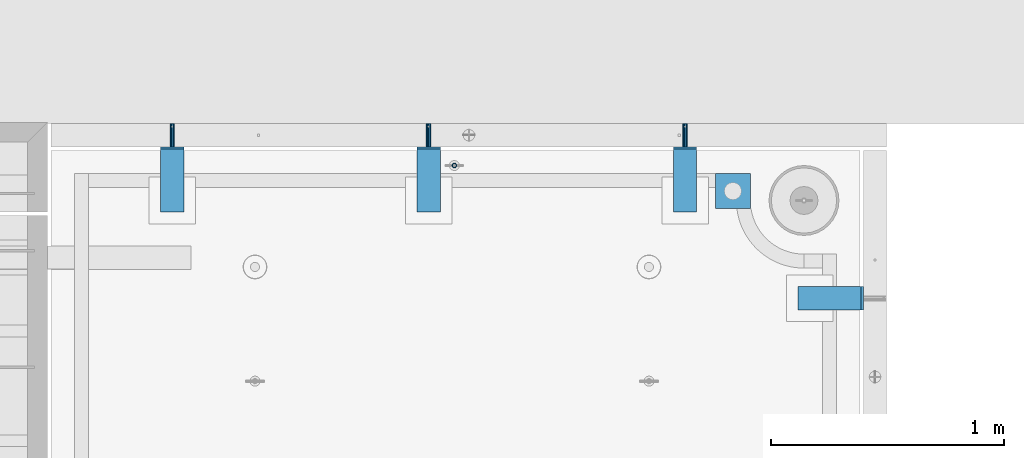
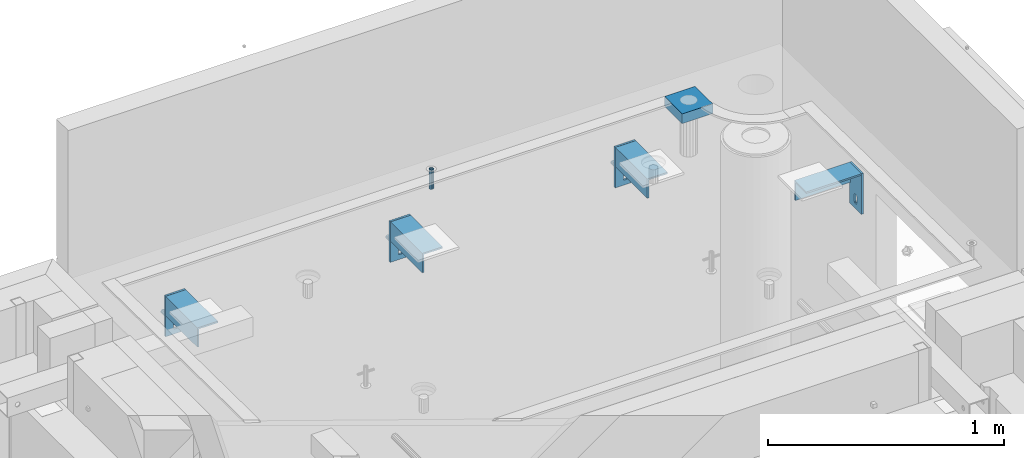
# One storey, part 114 of 264: 13 beams, 14 elements without a shape of their own.
"""IFC2X3 building model written with IfcOpenShell, lengths in millimetres."""

from ifc_helpers import new_model, si_unit, frame, origin_with_axes, place, context, subcontext, project, spatial, faceted_brep, material, type_object, element, aggregate, save


model = new_model("IFC2X3")

# Units and contexts
model_context = context("Model", 3, precision=1e-05, world=origin_with_axes())
body_context = subcontext(model_context, "Body", "Model", "MODEL_VIEW")
ifc_project = project(units=[si_unit("LENGTHUNIT", "METRE", prefix="MILLI"), si_unit("AREAUNIT", "SQUARE_METRE"), si_unit("VOLUMEUNIT", "CUBIC_METRE"), si_unit("MASSUNIT", "GRAM", prefix="KILO"), si_unit("TIMEUNIT", "SECOND"), si_unit("PLANEANGLEUNIT", "RADIAN"), si_unit("SOLIDANGLEUNIT", "STERADIAN"), si_unit("THERMODYNAMICTEMPERATUREUNIT", "DEGREE_CELSIUS"), si_unit("LUMINOUSINTENSITYUNIT", "LUMEN")], contexts=[model_context])

# Site, building, storey
site_placement = place(None, origin_with_axes())
site = spatial("IfcSite", under=ifc_project, at=site_placement, CompositionType="ELEMENT")
building_placement = place(site_placement, origin_with_axes())
building = spatial("IfcBuilding", under=site, at=building_placement, CompositionType="ELEMENT")
storey_placement = place(building_placement, origin_with_axes())
storey = spatial("IfcBuildingStorey", under=building, at=storey_placement, Name="K", CompositionType="ELEMENT", Elevation=0.0)

# Assembly, beam
assembly_1_placement = place(storey_placement, origin_with_axes())
assembly_1 = element("IfcElementAssembly", 1, at=assembly_1_placement, inside=storey, AssemblyPlace="NOTDEFINED", PredefinedType="REINFORCEMENT_UNIT")
ifc_material_1 = material(Name="CONCRETE/Concrete_Undefined")
beam_type_1 = type_object("IfcBeamType", PredefinedType="NOTDEFINED")
beam_1_placement = place(assembly_1_placement, frame((34629.9388785763, 22710.0581582943, 81683.7829850799), z_axis=(-0.00137996799978526, 4.79999998713041e-07, 0.999999047843591), x_axis=(0.999998987436327, -0.000347584000148161, 0.00137996800063524)))
beam_1 = element("IfcBeam", 2, at=beam_1_placement, type_object=beam_type_1, material=ifc_material_1, context=body_context, shape_type="Brep", body=[
    faceted_brep([(0.0, 75.0, -25.0), (1.81898940354586e-12, 75.0, 25.0), (149.995899162379, 75.0, 25.0), (149.995899158246, 75.0000000000036, -25.0), (1.81898940354586e-12, -75.0000000000009, 25.0), (149.995899162386, -75.0, 25.0), (0.0, -75.0, -25.0), (149.995899158239, -74.9999999999964, -25.0)], [[[0, 1, 2, 3]], [[1, 4, 5, 2]], [[4, 6, 7, 5]], [[6, 0, 3, 7]], [[5, 7, 3, 2]], [[6, 4, 1, 0]]]),
])

# Assemblies, beams
assembly_2_placement = place(storey_placement, origin_with_axes())
assembly_2 = element("IfcElementAssembly", 3, at=assembly_2_placement, inside=storey, AssemblyPlace="NOTDEFINED", PredefinedType="REINFORCEMENT_UNIT")
assembly_3_placement = place(assembly_2_placement, origin_with_axes())
assembly_3 = element("IfcElementAssembly", 4, at=assembly_3_placement, Name="Steel Assembly", AssemblyPlace="NOTDEFINED", PredefinedType="RIGID_FRAME")
ifc_material_2 = material(Name="STEEL/1.4301")
beam_type_2 = type_object("IfcBeamType", PredefinedType="NOTDEFINED")
beam_2_placement = place(assembly_3_placement, frame((32299.9965310378, 22900.0002194488, 81285.0), z_axis=(1.0, 0.0, 0.0), x_axis=(0.0, 1.0, 0.0)))
beam_2 = element("IfcBeam", 5, at=beam_2_placement, type_object=beam_type_2, material=ifc_material_2, context=body_context, shape_type="Brep", body=[
    faceted_brep([(0.0, -8.49999999999272, -1.45519152283669e-11), (0.0, -7.36121593215648, 4.24999999998545), (100.000000000262, -7.36121593215648, 4.24999999998545), (100.000000000262, -8.49999999999272, -1.45519152283669e-11), (0.0, -4.24999999998545, 7.36121593216376), (100.000000000262, -4.24999999998545, 7.36121593216376), (0.0, 1.45519152283669e-11, 8.49999999998545), (100.000000000262, 1.45519152283669e-11, 8.49999999998545), (0.0, 4.25000000001455, 7.36121593216376), (100.000000000262, 4.25000000001455, 7.36121593216376), (0.0, 7.36121593217104, 4.24999999998545), (100.000000000262, 7.36121593217104, 4.24999999998545), (0.0, 8.50000000000728, 0.0), (100.000000000262, 8.50000000000728, 0.0), (0.0, 7.36121593217104, -4.25000000001455), (100.000000000262, 7.36121593217104, -4.25000000001455), (0.0, 4.25000000000728, -7.36121593219286), (100.000000000262, 4.25000000000728, -7.36121593219286), (0.0, 7.27595761418343e-12, -8.5), (100.000000000262, 7.27595761418343e-12, -8.5), (0.0, -4.24999999999272, -7.36121593217831), (100.000000000262, -4.24999999999272, -7.36121593217831), (0.0, -7.36121593215648, -4.25), (100.000000000262, -7.36121593215648, -4.25), (0.0, -10.4999999999927, -1.45519152283669e-11), (0.0, -9.09326673972828, -5.25000000001455), (100.000000000262, -9.09326673972828, -5.25000000001455), (100.000000000262, -10.4999999999927, -1.45519152283669e-11), (0.0, -5.24999999998545, -9.09326673974283), (100.000000000262, -5.24999999998545, -9.09326673974283), (0.0, 7.27595761418343e-12, -10.5), (100.000000000262, 7.27595761418343e-12, -10.5), (0.0, 5.25000000001455, -9.09326673975738), (100.000000000262, 5.25000000001455, -9.09326673975738), (0.0, 9.09326673975011, -5.25000000001455), (100.000000000262, 9.09326673975011, -5.25000000001455), (0.0, 10.5000000000073, -1.45519152283669e-11), (100.000000000262, 10.5000000000073, -1.45519152283669e-11), (0.0, 9.09326673975011, 5.25), (100.000000000262, 9.09326673975011, 5.25), (0.0, 5.25000000000728, 9.09326673972828), (100.000000000262, 5.25000000000728, 9.09326673972828), (0.0, 1.45519152283669e-11, 10.4999999999854), (100.000000000262, 1.45519152283669e-11, 10.4999999999854), (0.0, -5.24999999999272, 9.09326673972828), (100.000000000262, -5.24999999999272, 9.09326673972828), (0.0, -9.09326673972828, 5.24999999998545), (100.000000000262, -9.09326673972828, 5.24999999998545)], [[[0, 1, 2, 3]], [[1, 4, 5, 2]], [[4, 6, 7, 5]], [[6, 8, 9, 7]], [[8, 10, 11, 9]], [[10, 12, 13, 11]], [[12, 14, 15, 13]], [[14, 16, 17, 15]], [[16, 18, 19, 17]], [[18, 20, 21, 19]], [[20, 22, 23, 21]], [[22, 0, 3, 23]], [[24, 25, 26, 27]], [[25, 28, 29, 26]], [[28, 30, 31, 29]], [[30, 32, 33, 31]], [[32, 34, 35, 33]], [[34, 36, 37, 35]], [[36, 38, 39, 37]], [[38, 40, 41, 39]], [[40, 42, 43, 41]], [[42, 44, 45, 43]], [[44, 46, 47, 45]], [[46, 24, 27, 47]], [[29, 31, 33, 35, 37, 39, 41, 43, 45, 47, 27, 26], [5, 7, 9, 11, 13, 15, 17, 19, 21, 23, 3, 2]], [[46, 44, 42, 40, 38, 36, 34, 32, 30, 28, 25, 24], [22, 20, 18, 16, 14, 12, 10, 8, 6, 4, 1, 0]]]),
])
aggregate(assembly_3, [beam_2])
assembly_4_placement = place(assembly_2_placement, origin_with_axes())
assembly_4 = element("IfcElementAssembly", 6, at=assembly_4_placement, Name="Steel Assembly", AssemblyPlace="NOTDEFINED", PredefinedType="RIGID_FRAME")
beam_3_placement = place(assembly_4_placement, frame((33399.9965310378, 22900.0002194488, 81285.0), z_axis=(1.0, 0.0, 0.0), x_axis=(0.0, 1.0, 0.0)))
beam_3 = element("IfcBeam", 7, at=beam_3_placement, type_object=beam_type_2, material=ifc_material_2, context=body_context, shape_type="Brep", body=[
    faceted_brep([(0.0, -8.49999999999272, -1.45519152283669e-11), (0.0, -7.36121593215648, 4.24999999998545), (100.000000000262, -7.36121593215648, 4.24999999998545), (100.000000000262, -8.49999999999272, -1.45519152283669e-11), (0.0, -4.24999999998545, 7.36121593216376), (100.000000000262, -4.24999999998545, 7.36121593216376), (0.0, 1.45519152283669e-11, 8.49999999998545), (100.000000000262, 1.45519152283669e-11, 8.49999999998545), (0.0, 4.25000000001455, 7.36121593216376), (100.000000000262, 4.25000000001455, 7.36121593216376), (0.0, 7.36121593217104, 4.24999999998545), (100.000000000262, 7.36121593217104, 4.24999999998545), (0.0, 8.50000000000728, 0.0), (100.000000000262, 8.50000000000728, 0.0), (0.0, 7.36121593217104, -4.25000000001455), (100.000000000262, 7.36121593217104, -4.25000000001455), (0.0, 4.25000000000728, -7.36121593219286), (100.000000000262, 4.25000000000728, -7.36121593219286), (0.0, 7.27595761418343e-12, -8.5), (100.000000000262, 7.27595761418343e-12, -8.5), (0.0, -4.24999999999272, -7.36121593217831), (100.000000000262, -4.24999999999272, -7.36121593217831), (0.0, -7.36121593215648, -4.25), (100.000000000262, -7.36121593215648, -4.25), (0.0, -10.4999999999927, -1.45519152283669e-11), (0.0, -9.09326673972828, -5.25000000001455), (100.000000000262, -9.09326673972828, -5.25000000001455), (100.000000000262, -10.4999999999927, -1.45519152283669e-11), (0.0, -5.24999999998545, -9.09326673974283), (100.000000000262, -5.24999999998545, -9.09326673974283), (0.0, 7.27595761418343e-12, -10.5), (100.000000000262, 7.27595761418343e-12, -10.5), (0.0, 5.25000000001455, -9.09326673975738), (100.000000000262, 5.25000000001455, -9.09326673975738), (0.0, 9.09326673975011, -5.25000000001455), (100.000000000262, 9.09326673975011, -5.25000000001455), (0.0, 10.5000000000073, -1.45519152283669e-11), (100.000000000262, 10.5000000000073, -1.45519152283669e-11), (0.0, 9.09326673975011, 5.25), (100.000000000262, 9.09326673975011, 5.25), (0.0, 5.25000000000728, 9.09326673972828), (100.000000000262, 5.25000000000728, 9.09326673972828), (0.0, 1.45519152283669e-11, 10.4999999999854), (100.000000000262, 1.45519152283669e-11, 10.4999999999854), (0.0, -5.24999999999272, 9.09326673972828), (100.000000000262, -5.24999999999272, 9.09326673972828), (0.0, -9.09326673972828, 5.24999999998545), (100.000000000262, -9.09326673972828, 5.24999999998545)], [[[0, 1, 2, 3]], [[1, 4, 5, 2]], [[4, 6, 7, 5]], [[6, 8, 9, 7]], [[8, 10, 11, 9]], [[10, 12, 13, 11]], [[12, 14, 15, 13]], [[14, 16, 17, 15]], [[16, 18, 19, 17]], [[18, 20, 21, 19]], [[20, 22, 23, 21]], [[22, 0, 3, 23]], [[24, 25, 26, 27]], [[25, 28, 29, 26]], [[28, 30, 31, 29]], [[30, 32, 33, 31]], [[32, 34, 35, 33]], [[34, 36, 37, 35]], [[36, 38, 39, 37]], [[38, 40, 41, 39]], [[40, 42, 43, 41]], [[42, 44, 45, 43]], [[44, 46, 47, 45]], [[46, 24, 27, 47]], [[29, 31, 33, 35, 37, 39, 41, 43, 45, 47, 27, 26], [5, 7, 9, 11, 13, 15, 17, 19, 21, 23, 3, 2]], [[46, 44, 42, 40, 38, 36, 34, 32, 30, 28, 25, 24], [22, 20, 18, 16, 14, 12, 10, 8, 6, 4, 1, 0]]]),
])
aggregate(assembly_4, [beam_3])
assembly_5_placement = place(assembly_2_placement, origin_with_axes())
assembly_5 = element("IfcElementAssembly", 8, at=assembly_5_placement, Name="Steel Assembly", AssemblyPlace="NOTDEFINED", PredefinedType="RIGID_FRAME")
aggregate(assembly_2, [assembly_3, assembly_4, assembly_5])
beam_4_placement = place(assembly_5_placement, frame((34499.9965310378, 22900.0002194488, 81285.0), z_axis=(1.0, 0.0, 0.0), x_axis=(0.0, 1.0, 0.0)))
beam_4 = element("IfcBeam", 9, at=beam_4_placement, type_object=beam_type_2, material=ifc_material_2, context=body_context, shape_type="Brep", body=[
    faceted_brep([(0.0, -8.49999999999272, -1.45519152283669e-11), (0.0, -7.36121593215648, 4.24999999998545), (100.000000000262, -7.36121593215648, 4.24999999998545), (100.000000000262, -8.49999999999272, -1.45519152283669e-11), (0.0, -4.24999999998545, 7.36121593216376), (100.000000000262, -4.24999999998545, 7.36121593216376), (0.0, 1.45519152283669e-11, 8.49999999998545), (100.000000000262, 1.45519152283669e-11, 8.49999999998545), (0.0, 4.25000000001455, 7.36121593216376), (100.000000000262, 4.25000000001455, 7.36121593216376), (0.0, 7.36121593217104, 4.24999999998545), (100.000000000262, 7.36121593217104, 4.24999999998545), (0.0, 8.50000000000728, 0.0), (100.000000000262, 8.50000000000728, 0.0), (0.0, 7.36121593217104, -4.25000000001455), (100.000000000262, 7.36121593217104, -4.25000000001455), (0.0, 4.25000000000728, -7.36121593219286), (100.000000000262, 4.25000000000728, -7.36121593219286), (0.0, 7.27595761418343e-12, -8.5), (100.000000000262, 7.27595761418343e-12, -8.5), (0.0, -4.24999999999272, -7.36121593217831), (100.000000000262, -4.24999999999272, -7.36121593217831), (0.0, -7.36121593215648, -4.25), (100.000000000262, -7.36121593215648, -4.25), (0.0, -10.4999999999927, -1.45519152283669e-11), (0.0, -9.09326673972828, -5.25000000001455), (100.000000000262, -9.09326673972828, -5.25000000001455), (100.000000000262, -10.4999999999927, -1.45519152283669e-11), (0.0, -5.24999999998545, -9.09326673974283), (100.000000000262, -5.24999999998545, -9.09326673974283), (0.0, 7.27595761418343e-12, -10.5), (100.000000000262, 7.27595761418343e-12, -10.5), (0.0, 5.25000000001455, -9.09326673975738), (100.000000000262, 5.25000000001455, -9.09326673975738), (0.0, 9.09326673975011, -5.25000000001455), (100.000000000262, 9.09326673975011, -5.25000000001455), (0.0, 10.5000000000073, -1.45519152283669e-11), (100.000000000262, 10.5000000000073, -1.45519152283669e-11), (0.0, 9.09326673975011, 5.25), (100.000000000262, 9.09326673975011, 5.25), (0.0, 5.25000000000728, 9.09326673972828), (100.000000000262, 5.25000000000728, 9.09326673972828), (0.0, 1.45519152283669e-11, 10.4999999999854), (100.000000000262, 1.45519152283669e-11, 10.4999999999854), (0.0, -5.24999999999272, 9.09326673972828), (100.000000000262, -5.24999999999272, 9.09326673972828), (0.0, -9.09326673972828, 5.24999999998545), (100.000000000262, -9.09326673972828, 5.24999999998545)], [[[0, 1, 2, 3]], [[1, 4, 5, 2]], [[4, 6, 7, 5]], [[6, 8, 9, 7]], [[8, 10, 11, 9]], [[10, 12, 13, 11]], [[12, 14, 15, 13]], [[14, 16, 17, 15]], [[16, 18, 19, 17]], [[18, 20, 21, 19]], [[20, 22, 23, 21]], [[22, 0, 3, 23]], [[24, 25, 26, 27]], [[25, 28, 29, 26]], [[28, 30, 31, 29]], [[30, 32, 33, 31]], [[32, 34, 35, 33]], [[34, 36, 37, 35]], [[36, 38, 39, 37]], [[38, 40, 41, 39]], [[40, 42, 43, 41]], [[42, 44, 45, 43]], [[44, 46, 47, 45]], [[46, 24, 27, 47]], [[29, 31, 33, 35, 37, 39, 41, 43, 45, 47, 27, 26], [5, 7, 9, 11, 13, 15, 17, 19, 21, 23, 3, 2]], [[46, 44, 42, 40, 38, 36, 34, 32, 30, 28, 25, 24], [22, 20, 18, 16, 14, 12, 10, 8, 6, 4, 1, 0]]]),
])
aggregate(assembly_5, [beam_4])

# Assembly
assembly_6_placement = place(assembly_1_placement, origin_with_axes())
assembly_6 = element("IfcElementAssembly", 10, at=assembly_6_placement, Name="Steel Assembly", AssemblyPlace="NOTDEFINED", PredefinedType="RIGID_FRAME")

aggregate(assembly_1, [assembly_6, beam_1])

# Beam
beam_type_3 = type_object("IfcBeamType", PredefinedType="NOTDEFINED")
beam_5_placement = place(assembly_6_placement, frame((33509.9967136813, 22819.9969702007, 81706.0000000179), z_axis=(1.19800000174933e-06, -0.999999999999282, 0.0), x_axis=(-4.36599999292741e-06, 0.0, -0.999999999990469)))
beam_5 = element("IfcBeam", 11, at=beam_5_placement, type_object=beam_type_3, material=ifc_material_2, context=body_context, shape_type="Brep", body=[
    faceted_brep([(0.0, -8.0, 0.0), (0.0, -6.92820323027263, 4.0), (100.000000000029, -6.92820323027263, 4.0), (100.000000000029, -7.99999999999636, 0.0), (0.0, -4.0, 6.92820323027627), (100.000000000029, -4.0, 6.92820323027536), (0.0, 0.0, 8.0), (100.000000000029, 3.63797880709171e-12, 8.0), (0.0, 4.0, 6.92820323027627), (100.000000000029, 4.0, 6.92820323027536), (0.0, 6.92820323027263, 4.0), (100.000000000029, 6.92820323027627, 3.99999999999909), (0.0, 8.0, 0.0), (100.000000000029, 8.0, 0.0), (0.0, 6.92820323027263, -4.0), (100.000000000029, 6.92820323027627, -4.00000000000091), (0.0, 4.0, -6.92820323027627), (100.000000000029, 4.00000000000364, -6.92820323027536), (0.0, 0.0, -8.0), (100.000000000029, 3.63797880709171e-12, -8.00000000000091), (0.0, -4.0, -6.92820323027627), (100.000000000029, -3.99999999999636, -6.92820323027627), (0.0, -6.92820323027263, -4.0), (100.000000000029, -6.92820323027263, -4.0), (0.0, -10.4999999999927, -1.45519152283669e-11), (0.0, -9.09326673972828, -5.25000000001455), (100.000000000262, -9.09326673972828, -5.25000000001455), (100.000000000262, -10.4999999999927, -1.45519152283669e-11), (0.0, -5.24999999998545, -9.09326673974283), (100.000000000262, -5.24999999998545, -9.09326673974283), (0.0, 7.27595761418343e-12, -10.5), (100.000000000262, 7.27595761418343e-12, -10.5), (0.0, 5.25000000001455, -9.09326673975738), (100.000000000262, 5.25000000001455, -9.09326673975738), (0.0, 9.09326673975011, -5.25000000001455), (100.000000000262, 9.09326673975011, -5.25000000001455), (0.0, 10.5000000000073, -1.45519152283669e-11), (100.000000000262, 10.5000000000073, -1.45519152283669e-11), (0.0, 9.09326673975011, 5.25), (100.000000000262, 9.09326673975011, 5.25), (0.0, 5.25000000000728, 9.09326673972828), (100.000000000262, 5.25000000000728, 9.09326673972828), (0.0, 1.45519152283669e-11, 10.4999999999854), (100.000000000262, 1.45519152283669e-11, 10.4999999999854), (0.0, -5.24999999999272, 9.09326673972828), (100.000000000262, -5.24999999999272, 9.09326673972828), (0.0, -9.09326673972828, 5.24999999998545), (100.000000000262, -9.09326673972828, 5.24999999998545)], [[[0, 1, 2, 3]], [[1, 4, 5, 2]], [[4, 6, 7, 5]], [[6, 8, 9, 7]], [[8, 10, 11, 9]], [[10, 12, 13, 11]], [[12, 14, 15, 13]], [[14, 16, 17, 15]], [[16, 18, 19, 17]], [[18, 20, 21, 19]], [[20, 22, 23, 21]], [[22, 0, 3, 23]], [[24, 25, 26, 27]], [[25, 28, 29, 26]], [[28, 30, 31, 29]], [[30, 32, 33, 31]], [[32, 34, 35, 33]], [[34, 36, 37, 35]], [[36, 38, 39, 37]], [[38, 40, 41, 39]], [[40, 42, 43, 41]], [[42, 44, 45, 43]], [[44, 46, 47, 45]], [[46, 24, 27, 47]], [[29, 31, 33, 35, 37, 39, 41, 43, 45, 47, 27, 26], [5, 7, 9, 11, 13, 15, 17, 19, 21, 23, 3, 2]], [[46, 44, 42, 40, 38, 36, 34, 32, 30, 28, 25, 24], [22, 20, 18, 16, 14, 12, 10, 8, 6, 4, 1, 0]]]),
])

aggregate(assembly_6, [beam_5])

# Assembly, beam
assembly_7_placement = place(storey_placement, origin_with_axes())
assembly_7 = element("IfcElementAssembly", 12, at=assembly_7_placement, inside=storey, Name="Steel Assembly", AssemblyPlace="NOTDEFINED", PredefinedType="RIGID_FRAME")
beam_type_4 = type_object("IfcBeamType", PredefinedType="NOTDEFINED")
beam_6_placement = place(assembly_7_placement, frame((35260.0002194488, 22300.0035213377, 81340.0), z_axis=(0.0, 0.0, -1.0), x_axis=(0.0, -1.0, 0.0)))
beam_6 = element("IfcBeam", 13, at=beam_6_placement, type_object=beam_type_4, material=ifc_material_2, context=body_context, shape_type="Brep", body=[
    faceted_brep([(39.0000000000073, -5.0, 72.0000000000146), (39.0000000000073, 5.0, 72.0000000000146), (39.6089637399164, 5.0, 75.0614674589306), (39.6089637399164, -5.0, 75.0614674589306), (41.3431457505139, 5.0, 77.6568542495079), (41.3431457505139, -5.0, 77.6568542495079), (43.9385325410876, 5.0, 79.3910362601018), (43.9385325410876, -5.0, 79.3910362601018), (47.0000000000073, 5.0, 80.0000000000146), (47.0000000000073, -5.0, 80.0000000000146), (53.0000000000073, 5.0, 80.0000000000146), (53.0000000000073, -5.0, 80.0000000000146), (56.0614674589269, 5.0, 79.3910362601018), (56.0614674589269, -5.0, 79.3910362601018), (58.6568542495006, 5.0, 77.6568542495079), (58.6568542495006, -5.0, 77.6568542495079), (60.3910362600982, 5.0, 75.0614674589306), (60.3910362600982, -5.0, 75.0614674589306), (61.0000000000073, 5.0, 72.0000000000146), (61.0000000000073, -5.0, 72.0000000000146), (61.0000000000036, 5.0, 38.0000000000146), (61.0000000000036, -5.0, 38.0000000000146), (60.3910362600946, 5.0, 34.9385325410985), (60.3910362600946, -5.0, 34.9385325410985), (58.656854249497, 5.0, 32.3431457505212), (58.656854249497, -5.0, 32.3431457505212), (56.0614674589233, 5.0, 30.6089637399273), (56.0614674589233, -5.0, 30.6089637399273), (53.0000000000036, 5.0, 30.0000000000146), (53.0000000000036, -5.0, 30.0000000000146), (47.0000000000073, 5.0, 30.0000000000146), (47.0000000000073, -5.0, 30.0000000000146), (43.9385325410876, 5.0, 30.6089637399273), (43.9385325410876, -5.0, 30.6089637399273), (41.3431457505139, 5.0, 32.3431457505212), (41.3431457505139, -5.0, 32.3431457505212), (39.6089637399164, 5.0, 34.9385325410985), (39.6089637399164, -5.0, 34.9385325410985), (39.0000000000073, 5.0, 38.0000000000146), (39.0000000000073, -5.0, 38.0000000000146), (0.0, -5.0, 105.0), (0.0, -5.0, -105.0), (100.0, -5.0, -105.0), (100.0, -5.0, 105.0), (0.0, 5.0, 105.0), (100.0, 5.0, 105.0), (0.0, 5.0, -105.0), (100.0, 5.0, -105.0)], [[[0, 1, 2, 3]], [[3, 2, 4, 5]], [[5, 4, 6, 7]], [[7, 6, 8, 9]], [[9, 8, 10, 11]], [[11, 10, 12, 13]], [[13, 12, 14, 15]], [[15, 14, 16, 17]], [[17, 16, 18, 19]], [[19, 18, 20, 21]], [[21, 20, 22, 23]], [[23, 22, 24, 25]], [[25, 24, 26, 27]], [[27, 26, 28, 29]], [[29, 28, 30, 31]], [[31, 30, 32, 33]], [[33, 32, 34, 35]], [[35, 34, 36, 37]], [[37, 36, 38, 39]], [[39, 38, 1, 0]], [[40, 41, 42, 43], [3, 5, 7, 9, 11, 13, 15, 17, 19, 21, 23, 25, 27, 29, 31, 33, 35, 37, 39, 0]], [[44, 40, 43, 45]], [[41, 40, 44, 46]], [[41, 46, 47, 42]], [[43, 42, 47, 45]], [[46, 44, 45, 47], [34, 32, 30, 28, 26, 24, 22, 20, 18, 16, 14, 12, 10, 8, 6, 4, 2, 1, 38, 36]]]),
])
aggregate(assembly_7, [beam_6])

assembly_8_placement = place(storey_placement, origin_with_axes())
assembly_8 = element("IfcElementAssembly", 14, at=assembly_8_placement, inside=storey, Name="Steel Assembly", AssemblyPlace="NOTDEFINED", PredefinedType="RIGID_FRAME")
beam_7_placement = place(assembly_8_placement, frame((34449.9964786623, 22895.0002194488, 81340.0), z_axis=(0.0, 0.0, -1.0), x_axis=(1.0, 0.0, 0.0)))
beam_7 = element("IfcBeam", 15, at=beam_7_placement, type_object=beam_type_4, material=ifc_material_2, context=body_context, shape_type="Brep", body=[
    faceted_brep([(60.3910362600946, -5.0, 34.9385325410985), (60.3910362600946, 5.0, 34.9385325410985), (58.656854249497, 5.0, 32.3431457505212), (58.656854249497, -5.0, 32.3431457505212), (56.0614674589233, 5.0, 30.6089637399273), (56.0614674589233, -5.0, 30.6089637399273), (53.0000000000036, 5.0, 30.0000000000146), (53.0000000000036, -5.0, 30.0000000000146), (47.0000000000073, 5.0, 30.0000000000146), (47.0000000000073, -5.0, 30.0000000000146), (43.9385325410876, 5.0, 30.6089637399273), (43.9385325410876, -5.0, 30.6089637399273), (41.3431457505139, 5.0, 32.3431457505212), (41.3431457505139, -5.0, 32.3431457505212), (39.6089637399164, 5.0, 34.9385325410985), (39.6089637399164, -5.0, 34.9385325410985), (39.0000000000073, 5.0, 38.0000000000146), (39.0000000000073, -5.0, 38.0000000000146), (39.0000000000073, 5.0, 72.0000000000146), (39.0000000000073, -5.0, 72.0000000000146), (39.6089637399164, 5.0, 75.0614674589306), (39.6089637399164, -5.0, 75.0614674589306), (41.3431457505139, 5.0, 77.6568542495079), (41.3431457505139, -5.0, 77.6568542495079), (43.9385325410876, 5.0, 79.3910362601018), (43.9385325410876, -5.0, 79.3910362601018), (47.0000000000073, 5.0, 80.0000000000146), (47.0000000000073, -5.0, 80.0000000000146), (53.0000000000073, 5.0, 80.0000000000146), (53.0000000000073, -5.0, 80.0000000000146), (56.0614674589269, 5.0, 79.3910362601018), (56.0614674589269, -5.0, 79.3910362601018), (58.6568542495006, 5.0, 77.6568542495079), (58.6568542495006, -5.0, 77.6568542495079), (60.3910362600982, 5.0, 75.0614674589306), (60.3910362600982, -5.0, 75.0614674589306), (61.0000000000073, 5.0, 72.0000000000146), (61.0000000000073, -5.0, 72.0000000000146), (61.0000000000036, 5.0, 38.0000000000146), (61.0000000000036, -5.0, 38.0000000000146), (0.0, -5.0, 105.0), (0.0, -5.0, -105.0), (100.0, -5.0, -105.0), (100.0, -5.0, 105.0), (0.0, 5.0, 105.0), (100.0, 5.0, 105.0), (0.0, 5.0, -105.0), (100.0, 5.0, -105.0)], [[[0, 1, 2, 3]], [[3, 2, 4, 5]], [[5, 4, 6, 7]], [[7, 6, 8, 9]], [[9, 8, 10, 11]], [[11, 10, 12, 13]], [[13, 12, 14, 15]], [[15, 14, 16, 17]], [[17, 16, 18, 19]], [[19, 18, 20, 21]], [[21, 20, 22, 23]], [[23, 22, 24, 25]], [[25, 24, 26, 27]], [[27, 26, 28, 29]], [[29, 28, 30, 31]], [[31, 30, 32, 33]], [[33, 32, 34, 35]], [[35, 34, 36, 37]], [[37, 36, 38, 39]], [[39, 38, 1, 0]], [[40, 41, 42, 43], [21, 23, 25, 27, 29, 31, 33, 35, 37, 39, 0, 3, 5, 7, 9, 11, 13, 15, 17, 19]], [[44, 40, 43, 45]], [[41, 40, 44, 46]], [[41, 46, 47, 42]], [[43, 42, 47, 45]], [[46, 44, 45, 47], [12, 10, 8, 6, 4, 2, 1, 38, 36, 34, 32, 30, 28, 26, 24, 22, 20, 18, 16, 14]]]),
])
aggregate(assembly_8, [beam_7])

assembly_9_placement = place(storey_placement, origin_with_axes())
assembly_9 = element("IfcElementAssembly", 16, at=assembly_9_placement, inside=storey, Name="Steel Assembly", AssemblyPlace="NOTDEFINED", PredefinedType="RIGID_FRAME")
beam_8_placement = place(assembly_9_placement, frame((33349.9964786623, 22895.0002194488, 81340.0), z_axis=(0.0, 0.0, -1.0), x_axis=(1.0, 0.0, 0.0)))
beam_8 = element("IfcBeam", 17, at=beam_8_placement, type_object=beam_type_4, material=ifc_material_2, context=body_context, shape_type="Brep", body=[
    faceted_brep([(60.3910362600946, -5.0, 34.9385325410985), (60.3910362600946, 5.0, 34.9385325410985), (58.656854249497, 5.0, 32.3431457505212), (58.656854249497, -5.0, 32.3431457505212), (56.0614674589233, 5.0, 30.6089637399273), (56.0614674589233, -5.0, 30.6089637399273), (53.0000000000036, 5.0, 30.0000000000146), (53.0000000000036, -5.0, 30.0000000000146), (47.0000000000073, 5.0, 30.0000000000146), (47.0000000000073, -5.0, 30.0000000000146), (43.9385325410876, 5.0, 30.6089637399273), (43.9385325410876, -5.0, 30.6089637399273), (41.3431457505139, 5.0, 32.3431457505212), (41.3431457505139, -5.0, 32.3431457505212), (39.6089637399164, 5.0, 34.9385325410985), (39.6089637399164, -5.0, 34.9385325410985), (39.0000000000073, 5.0, 38.0000000000146), (39.0000000000073, -5.0, 38.0000000000146), (39.0000000000073, 5.0, 72.0000000000146), (39.0000000000073, -5.0, 72.0000000000146), (39.6089637399164, 5.0, 75.0614674589306), (39.6089637399164, -5.0, 75.0614674589306), (41.3431457505139, 5.0, 77.6568542495079), (41.3431457505139, -5.0, 77.6568542495079), (43.9385325410876, 5.0, 79.3910362601018), (43.9385325410876, -5.0, 79.3910362601018), (47.0000000000073, 5.0, 80.0000000000146), (47.0000000000073, -5.0, 80.0000000000146), (53.0000000000073, 5.0, 80.0000000000146), (53.0000000000073, -5.0, 80.0000000000146), (56.0614674589269, 5.0, 79.3910362601018), (56.0614674589269, -5.0, 79.3910362601018), (58.6568542495006, 5.0, 77.6568542495079), (58.6568542495006, -5.0, 77.6568542495079), (60.3910362600982, 5.0, 75.0614674589306), (60.3910362600982, -5.0, 75.0614674589306), (61.0000000000073, 5.0, 72.0000000000146), (61.0000000000073, -5.0, 72.0000000000146), (61.0000000000036, 5.0, 38.0000000000146), (61.0000000000036, -5.0, 38.0000000000146), (0.0, -5.0, 105.0), (0.0, -5.0, -105.0), (100.0, -5.0, -105.0), (100.0, -5.0, 105.0), (0.0, 5.0, 105.0), (100.0, 5.0, 105.0), (0.0, 5.0, -105.0), (100.0, 5.0, -105.0)], [[[0, 1, 2, 3]], [[3, 2, 4, 5]], [[5, 4, 6, 7]], [[7, 6, 8, 9]], [[9, 8, 10, 11]], [[11, 10, 12, 13]], [[13, 12, 14, 15]], [[15, 14, 16, 17]], [[17, 16, 18, 19]], [[19, 18, 20, 21]], [[21, 20, 22, 23]], [[23, 22, 24, 25]], [[25, 24, 26, 27]], [[27, 26, 28, 29]], [[29, 28, 30, 31]], [[31, 30, 32, 33]], [[33, 32, 34, 35]], [[35, 34, 36, 37]], [[37, 36, 38, 39]], [[39, 38, 1, 0]], [[40, 41, 42, 43], [21, 23, 25, 27, 29, 31, 33, 35, 37, 39, 0, 3, 5, 7, 9, 11, 13, 15, 17, 19]], [[44, 40, 43, 45]], [[41, 40, 44, 46]], [[41, 46, 47, 42]], [[43, 42, 47, 45]], [[46, 44, 45, 47], [12, 10, 8, 6, 4, 2, 1, 38, 36, 34, 32, 30, 28, 26, 24, 22, 20, 18, 16, 14]]]),
])
aggregate(assembly_9, [beam_8])

assembly_10_placement = place(storey_placement, origin_with_axes())
assembly_10 = element("IfcElementAssembly", 18, at=assembly_10_placement, inside=storey, Name="Steel Assembly", AssemblyPlace="NOTDEFINED", PredefinedType="RIGID_FRAME")
beam_9_placement = place(assembly_10_placement, frame((32249.9964786623, 22895.0002194488, 81340.0), z_axis=(0.0, 0.0, -1.0), x_axis=(1.0, 0.0, 0.0)))
beam_9 = element("IfcBeam", 19, at=beam_9_placement, type_object=beam_type_4, material=ifc_material_2, context=body_context, shape_type="Brep", body=[
    faceted_brep([(60.3910362600946, -5.0, 34.9385325410985), (60.3910362600946, 5.0, 34.9385325410985), (58.656854249497, 5.0, 32.3431457505212), (58.656854249497, -5.0, 32.3431457505212), (56.0614674589233, 5.0, 30.6089637399273), (56.0614674589233, -5.0, 30.6089637399273), (53.0000000000036, 5.0, 30.0000000000146), (53.0000000000036, -5.0, 30.0000000000146), (47.0000000000073, 5.0, 30.0000000000146), (47.0000000000073, -5.0, 30.0000000000146), (43.9385325410876, 5.0, 30.6089637399273), (43.9385325410876, -5.0, 30.6089637399273), (41.3431457505139, 5.0, 32.3431457505212), (41.3431457505139, -5.0, 32.3431457505212), (39.6089637399164, 5.0, 34.9385325410985), (39.6089637399164, -5.0, 34.9385325410985), (39.0000000000073, 5.0, 38.0000000000146), (39.0000000000073, -5.0, 38.0000000000146), (39.0000000000073, 5.0, 72.0000000000146), (39.0000000000073, -5.0, 72.0000000000146), (39.6089637399164, 5.0, 75.0614674589306), (39.6089637399164, -5.0, 75.0614674589306), (41.3431457505139, 5.0, 77.6568542495079), (41.3431457505139, -5.0, 77.6568542495079), (43.9385325410876, 5.0, 79.3910362601018), (43.9385325410876, -5.0, 79.3910362601018), (47.0000000000073, 5.0, 80.0000000000146), (47.0000000000073, -5.0, 80.0000000000146), (53.0000000000073, 5.0, 80.0000000000146), (53.0000000000073, -5.0, 80.0000000000146), (56.0614674589269, 5.0, 79.3910362601018), (56.0614674589269, -5.0, 79.3910362601018), (58.6568542495006, 5.0, 77.6568542495079), (58.6568542495006, -5.0, 77.6568542495079), (60.3910362600982, 5.0, 75.0614674589306), (60.3910362600982, -5.0, 75.0614674589306), (61.0000000000073, 5.0, 72.0000000000146), (61.0000000000073, -5.0, 72.0000000000146), (61.0000000000036, 5.0, 38.0000000000146), (61.0000000000036, -5.0, 38.0000000000146), (0.0, -5.0, 105.0), (0.0, -5.0, -105.0), (100.0, -5.0, -105.0), (100.0, -5.0, 105.0), (0.0, 5.0, 105.0), (100.0, 5.0, 105.0), (0.0, 5.0, -105.0), (100.0, 5.0, -105.0)], [[[0, 1, 2, 3]], [[3, 2, 4, 5]], [[5, 4, 6, 7]], [[7, 6, 8, 9]], [[9, 8, 10, 11]], [[11, 10, 12, 13]], [[13, 12, 14, 15]], [[15, 14, 16, 17]], [[17, 16, 18, 19]], [[19, 18, 20, 21]], [[21, 20, 22, 23]], [[23, 22, 24, 25]], [[25, 24, 26, 27]], [[27, 26, 28, 29]], [[29, 28, 30, 31]], [[31, 30, 32, 33]], [[33, 32, 34, 35]], [[35, 34, 36, 37]], [[37, 36, 38, 39]], [[39, 38, 1, 0]], [[40, 41, 42, 43], [21, 23, 25, 27, 29, 31, 33, 35, 37, 39, 0, 3, 5, 7, 9, 11, 13, 15, 17, 19]], [[44, 40, 43, 45]], [[41, 40, 44, 46]], [[41, 46, 47, 42]], [[43, 42, 47, 45]], [[46, 44, 45, 47], [12, 10, 8, 6, 4, 2, 1, 38, 36, 34, 32, 30, 28, 26, 24, 22, 20, 18, 16, 14]]]),
])
aggregate(assembly_10, [beam_9])

assembly_11_placement = place(storey_placement, origin_with_axes())
assembly_11 = element("IfcElementAssembly", 20, at=assembly_11_placement, inside=storey, Name="Steel Assembly", AssemblyPlace="NOTDEFINED", PredefinedType="RIGID_FRAME")
beam_type_5 = type_object("IfcBeamType", PredefinedType="NOTDEFINED")
beam_10_placement = place(assembly_11_placement, frame((34985.0002194488, 22250.0035213377, 81395.0), z_axis=(0.0, -1.0, 0.0), x_axis=(1.0, 0.0, 0.0)))
beam_10 = element("IfcBeam", 21, at=beam_10_placement, type_object=beam_type_5, material=ifc_material_2, Name="L", context=body_context, shape_type="Brep", body=[
    faceted_brep([(1.81898940354586e-12, 49.9999999999991, -50.0), (1.81898940354586e-12, 49.9999999999991, 50.0), (270.0, 50.0, 50.0), (270.0, 50.0, -50.0), (0.0, 42.0, 50.0), (270.0, 42.0, 50.0), (0.0, 42.0, -42.0), (270.0, 42.0, -42.0), (0.0, -50.0, -42.0), (270.0, -50.0, -42.0), (1.81898940354586e-12, -50.0000000000009, -50.0), (270.0, -50.0, -50.0)], [[[0, 1, 2, 3]], [[1, 4, 5, 2]], [[4, 6, 7, 5]], [[6, 8, 9, 7]], [[8, 10, 11, 9]], [[10, 0, 3, 11]], [[5, 7, 9, 11, 3, 2]], [[10, 8, 6, 4, 1, 0]]]),
])
aggregate(assembly_11, [beam_10])

assembly_12_placement = place(storey_placement, origin_with_axes())
assembly_12 = element("IfcElementAssembly", 22, at=assembly_12_placement, inside=storey, Name="Steel Assembly", AssemblyPlace="NOTDEFINED", PredefinedType="RIGID_FRAME")
beam_11_placement = place(assembly_12_placement, frame((34499.9964786623, 22620.0002194488, 81395.0), z_axis=(1.0, 0.0, 0.0), x_axis=(0.0, 1.0, 0.0)))
beam_11 = element("IfcBeam", 23, at=beam_11_placement, type_object=beam_type_5, material=ifc_material_2, Name="L", context=body_context, shape_type="Brep", body=[
    faceted_brep([(1.81898940354586e-12, 49.9999999999991, -50.0), (1.81898940354586e-12, 49.9999999999991, 50.0), (270.0, 50.0, 50.0), (270.0, 50.0, -50.0), (0.0, 42.0, 50.0), (270.0, 42.0, 50.0), (0.0, 42.0, -42.0), (270.0, 42.0, -42.0), (0.0, -50.0, -42.0), (270.0, -50.0, -42.0), (1.81898940354586e-12, -50.0000000000009, -50.0), (270.0, -50.0, -50.0)], [[[0, 1, 2, 3]], [[1, 4, 5, 2]], [[4, 6, 7, 5]], [[6, 8, 9, 7]], [[8, 10, 11, 9]], [[10, 0, 3, 11]], [[5, 7, 9, 11, 3, 2]], [[10, 8, 6, 4, 1, 0]]]),
])
aggregate(assembly_12, [beam_11])

assembly_13_placement = place(storey_placement, origin_with_axes())
assembly_13 = element("IfcElementAssembly", 24, at=assembly_13_placement, inside=storey, Name="Steel Assembly", AssemblyPlace="NOTDEFINED", PredefinedType="RIGID_FRAME")
beam_12_placement = place(assembly_13_placement, frame((33399.9964786623, 22620.0002194488, 81395.0), z_axis=(1.0, 0.0, 0.0), x_axis=(0.0, 1.0, 0.0)))
beam_12 = element("IfcBeam", 25, at=beam_12_placement, type_object=beam_type_5, material=ifc_material_2, Name="L", context=body_context, shape_type="Brep", body=[
    faceted_brep([(1.81898940354586e-12, 49.9999999999991, -50.0), (1.81898940354586e-12, 49.9999999999991, 50.0), (270.0, 50.0, 50.0), (270.0, 50.0, -50.0), (0.0, 42.0, 50.0), (270.0, 42.0, 50.0), (0.0, 42.0, -42.0), (270.0, 42.0, -42.0), (0.0, -50.0, -42.0), (270.0, -50.0, -42.0), (1.81898940354586e-12, -50.0000000000009, -50.0), (270.0, -50.0, -50.0)], [[[0, 1, 2, 3]], [[1, 4, 5, 2]], [[4, 6, 7, 5]], [[6, 8, 9, 7]], [[8, 10, 11, 9]], [[10, 0, 3, 11]], [[5, 7, 9, 11, 3, 2]], [[10, 8, 6, 4, 1, 0]]]),
])
aggregate(assembly_13, [beam_12])

assembly_14_placement = place(storey_placement, origin_with_axes())
assembly_14 = element("IfcElementAssembly", 26, at=assembly_14_placement, inside=storey, Name="Steel Assembly", AssemblyPlace="NOTDEFINED", PredefinedType="RIGID_FRAME")
beam_13_placement = place(assembly_14_placement, frame((32299.9964786623, 22620.0002194488, 81395.0), z_axis=(1.0, 0.0, 0.0), x_axis=(0.0, 1.0, 0.0)))
beam_13 = element("IfcBeam", 27, at=beam_13_placement, type_object=beam_type_5, material=ifc_material_2, Name="L", context=body_context, shape_type="Brep", body=[
    faceted_brep([(1.81898940354586e-12, 49.9999999999991, -50.0), (1.81898940354586e-12, 49.9999999999991, 50.0), (270.0, 50.0, 50.0), (270.0, 50.0, -50.0), (0.0, 42.0, 50.0), (270.0, 42.0, 50.0), (0.0, 42.0, -42.0), (270.0, 42.0, -42.0), (0.0, -50.0, -42.0), (270.0, -50.0, -42.0), (1.81898940354586e-12, -50.0000000000009, -50.0), (270.0, -50.0, -50.0)], [[[0, 1, 2, 3]], [[1, 4, 5, 2]], [[4, 6, 7, 5]], [[6, 8, 9, 7]], [[8, 10, 11, 9]], [[10, 0, 3, 11]], [[5, 7, 9, 11, 3, 2]], [[10, 8, 6, 4, 1, 0]]]),
])
aggregate(assembly_14, [beam_13])

save(model, "model.ifc")
